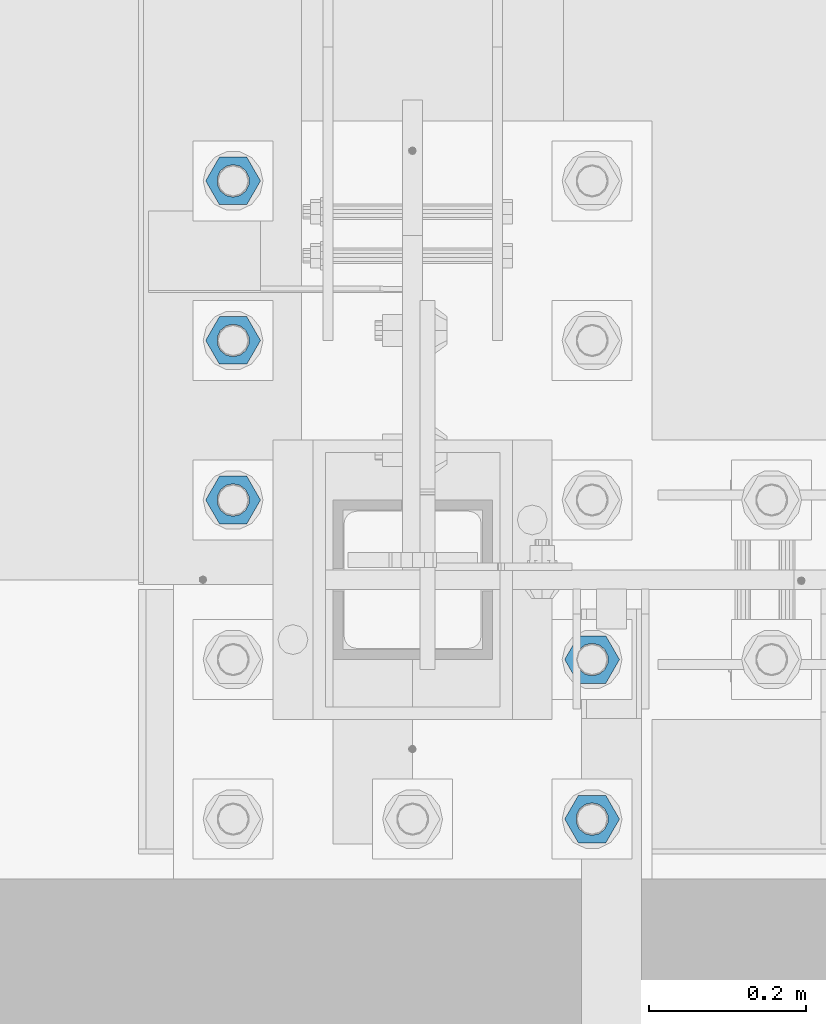
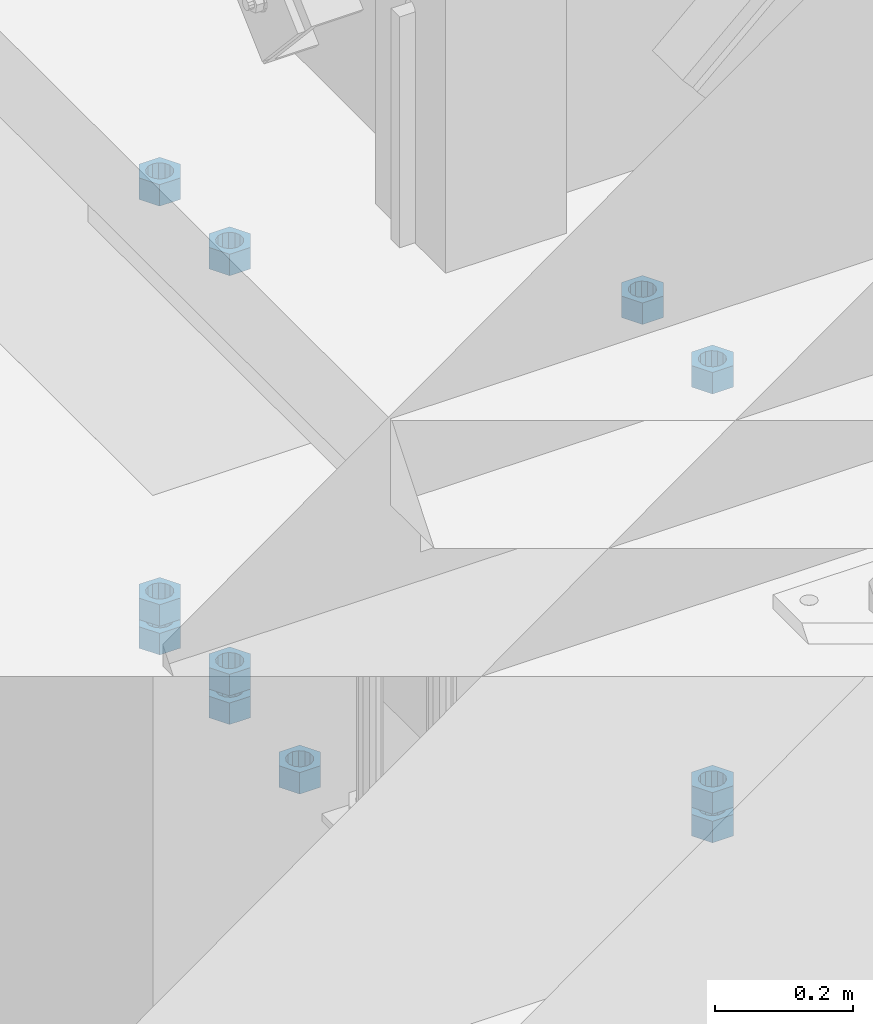
# One storey, part 979 of 1763: 11 columns, 1 element without a shape of its own.
"""IFC2X3 building model written with IfcOpenShell, lengths in millimetres."""

from ifc_helpers import new_model, si_unit, frame, origin_with_axes, place, context, subcontext, project, spatial, faceted_brep, material, type_object, element, aggregate, save


model = new_model("IFC2X3")

# Units and contexts
model_context = context("Model", 3, precision=1e-05, world=origin_with_axes())
body_context = subcontext(model_context, "Body", "Model", "MODEL_VIEW")
ifc_project = project(units=[si_unit("LENGTHUNIT", "METRE", prefix="MILLI"), si_unit("AREAUNIT", "SQUARE_METRE"), si_unit("VOLUMEUNIT", "CUBIC_METRE"), si_unit("MASSUNIT", "GRAM", prefix="KILO"), si_unit("TIMEUNIT", "SECOND"), si_unit("PLANEANGLEUNIT", "RADIAN"), si_unit("SOLIDANGLEUNIT", "STERADIAN"), si_unit("THERMODYNAMICTEMPERATUREUNIT", "DEGREE_CELSIUS"), si_unit("LUMINOUSINTENSITYUNIT", "LUMEN")], contexts=[model_context])

# Site, building, storey
site_placement = place(None, origin_with_axes())
site = spatial("IfcSite", under=ifc_project, at=site_placement, CompositionType="ELEMENT")
building_placement = place(site_placement, origin_with_axes())
building = spatial("IfcBuilding", under=site, at=building_placement, Name="Undefined", CompositionType="ELEMENT")
storey_placement = place(building_placement, origin_with_axes())
storey = spatial("IfcBuildingStorey", under=building, at=storey_placement, Name="Undefined", CompositionType="ELEMENT", Elevation=0.0)

# Assembly, columns
assembly_placement = place(storey_placement, origin_with_axes())
assembly = element("IfcElementAssembly", 1, at=assembly_placement, inside=storey, Name="TEMPLATE", AssemblyPlace="NOTDEFINED", PredefinedType="RIGID_FRAME")
ifc_material = material(Name="STEEL/A563")
column_type = type_object("IfcColumnType", Name="1-1/2_HEAVY_HEX_NUT", PredefinedType="NOTDEFINED")
column_1_placement = place(assembly_placement, frame((-87146.8372736983, -14020.8, 5189.53750000001), z_axis=(0.0, 1.0, 0.0), x_axis=(0.0, 0.0, -1.0)))
column_1 = element("IfcColumn", 2, at=column_1_placement, type_object=column_type, material=ifc_material, Name="NUT", ObjectType="1-1/2_HEAVY_HEX_NUT", context=body_context, shape_type="Brep", body=[
    faceted_brep([(0.0, -34.9199981689453, 0.0), (0.0, -17.4599990844727, -30.25), (38.1000000000004, -17.4599990844727, -30.25), (38.1000000000004, -34.9199981689453, 0.0), (0.0, 17.4599990844727, -30.25), (38.1000000000004, 17.4599990844727, -30.25), (0.0, 34.9199981689453, 0.0), (38.1000000000004, 34.9199981689453, 0.0), (0.0, 17.4599990844727, 30.25), (38.1000000000004, 17.4599990844727, 30.25), (0.0, -17.4599990844727, 30.25), (38.1000000000004, -17.4599990844727, 30.25), (0.0, 0.0, 20.6399993896484), (0.0, 8.95536011056538, 18.5959968835978), (38.1000000000004, 8.95536011056538, 18.5959968835978), (38.1000000000004, 0.0, 20.6399993896484), (0.0, 16.1370013209453, 12.8688291298167), (38.1000000000004, 16.1370013209453, 12.8688291298167), (0.0, 20.1225115123816, 4.59283194104137), (38.1000000000004, 20.1225115123816, 4.59283194104137), (0.0, 20.1225115123816, -4.59283194104319), (38.1000000000004, 20.1225115123816, -4.59283194104319), (0.0, 16.1370013209453, -12.8688291298167), (38.1000000000004, 16.1370013209453, -12.8688291298167), (0.0, 8.95536011056538, -18.5959968835978), (38.1000000000004, 8.95536011056538, -18.5959968835978), (0.0, 0.0, -20.6399993896484), (38.1000000000004, 0.0, -20.6399993896484), (0.0, -8.95536011056538, -18.5959968835978), (38.1000000000004, -8.95536011056538, -18.5959968835978), (0.0, -16.1370013209453, -12.8688291298167), (38.1000000000004, -16.1370013209453, -12.8688291298167), (0.0, -20.1225115123816, -4.59283194104137), (38.1000000000004, -20.1225115123816, -4.59283194104137), (0.0, -20.1225115123816, 4.59283194104319), (38.1000000000004, -20.1225115123816, 4.59283194104319), (0.0, -16.1370013209453, 12.8688291298167), (38.1000000000004, -16.1370013209453, 12.8688291298167), (0.0, -8.95536011056538, 18.5959968835978), (38.1000000000004, -8.95536011056538, 18.5959968835978)], [[[0, 1, 2, 3]], [[1, 4, 5, 2]], [[4, 6, 7, 5]], [[6, 8, 9, 7]], [[8, 10, 11, 9]], [[10, 0, 3, 11]], [[12, 13, 14, 15]], [[13, 16, 17, 14]], [[16, 18, 19, 17]], [[18, 20, 21, 19]], [[20, 22, 23, 21]], [[22, 24, 25, 23]], [[24, 26, 27, 25]], [[26, 28, 29, 27]], [[28, 30, 31, 29]], [[30, 32, 33, 31]], [[32, 34, 35, 33]], [[34, 36, 37, 35]], [[36, 38, 39, 37]], [[38, 12, 15, 39]], [[5, 7, 9, 11, 3, 2], [17, 19, 21, 23, 25, 27, 29, 31, 33, 35, 37, 39, 15, 14]], [[10, 8, 6, 4, 1, 0], [38, 36, 34, 32, 30, 28, 26, 24, 22, 20, 18, 16, 13, 12]]]),
])
column_2_placement = place(assembly_placement, frame((-87146.8372736983, -14020.8, 4445.00000000001), z_axis=(0.0, 1.0, 0.0), x_axis=(0.0, 0.0, -1.0)))
column_2 = element("IfcColumn", 3, at=column_2_placement, type_object=column_type, material=ifc_material, Name="NUT", ObjectType="1-1/2_HEAVY_HEX_NUT", context=body_context, shape_type="Brep", body=[
    faceted_brep([(0.0, -34.9199981689453, 0.0), (0.0, -17.4599990844727, -30.25), (38.1000000000004, -17.4599990844727, -30.25), (38.1000000000004, -34.9199981689453, 0.0), (0.0, 17.4599990844727, -30.25), (38.1000000000004, 17.4599990844727, -30.25), (0.0, 34.9199981689453, 0.0), (38.1000000000004, 34.9199981689453, 0.0), (0.0, 17.4599990844727, 30.25), (38.1000000000004, 17.4599990844727, 30.25), (0.0, -17.4599990844727, 30.25), (38.1000000000004, -17.4599990844727, 30.25), (0.0, 0.0, 20.6399993896484), (0.0, 8.95536011056538, 18.5959968835978), (38.1000000000004, 8.95536011056538, 18.5959968835978), (38.1000000000004, 0.0, 20.6399993896484), (0.0, 16.1370013209453, 12.8688291298167), (38.1000000000004, 16.1370013209453, 12.8688291298167), (0.0, 20.1225115123816, 4.59283194104137), (38.1000000000004, 20.1225115123816, 4.59283194104137), (0.0, 20.1225115123816, -4.59283194104319), (38.1000000000004, 20.1225115123816, -4.59283194104319), (0.0, 16.1370013209453, -12.8688291298167), (38.1000000000004, 16.1370013209453, -12.8688291298167), (0.0, 8.95536011056538, -18.5959968835978), (38.1000000000004, 8.95536011056538, -18.5959968835978), (0.0, 0.0, -20.6399993896484), (38.1000000000004, 0.0, -20.6399993896484), (0.0, -8.95536011056538, -18.5959968835978), (38.1000000000004, -8.95536011056538, -18.5959968835978), (0.0, -16.1370013209453, -12.8688291298167), (38.1000000000004, -16.1370013209453, -12.8688291298167), (0.0, -20.1225115123816, -4.59283194104137), (38.1000000000004, -20.1225115123816, -4.59283194104137), (0.0, -20.1225115123816, 4.59283194104319), (38.1000000000004, -20.1225115123816, 4.59283194104319), (0.0, -16.1370013209453, 12.8688291298167), (38.1000000000004, -16.1370013209453, 12.8688291298167), (0.0, -8.95536011056538, 18.5959968835978), (38.1000000000004, -8.95536011056538, 18.5959968835978)], [[[0, 1, 2, 3]], [[1, 4, 5, 2]], [[4, 6, 7, 5]], [[6, 8, 9, 7]], [[8, 10, 11, 9]], [[10, 0, 3, 11]], [[12, 13, 14, 15]], [[13, 16, 17, 14]], [[16, 18, 19, 17]], [[18, 20, 21, 19]], [[20, 22, 23, 21]], [[22, 24, 25, 23]], [[24, 26, 27, 25]], [[26, 28, 29, 27]], [[28, 30, 31, 29]], [[30, 32, 33, 31]], [[32, 34, 35, 33]], [[34, 36, 37, 35]], [[36, 38, 39, 37]], [[38, 12, 15, 39]], [[5, 7, 9, 11, 3, 2], [17, 19, 21, 23, 25, 27, 29, 31, 33, 35, 37, 39, 15, 14]], [[10, 8, 6, 4, 1, 0], [38, 36, 34, 32, 30, 28, 26, 24, 22, 20, 18, 16, 13, 12]]]),
])
column_3_placement = place(assembly_placement, frame((-87146.8372736983, -14020.8, 4394.20000000001), z_axis=(0.0, 1.0, 0.0), x_axis=(0.0, 0.0, -1.0)))
column_3 = element("IfcColumn", 4, at=column_3_placement, type_object=column_type, material=ifc_material, Name="NUT", ObjectType="1-1/2_HEAVY_HEX_NUT", context=body_context, shape_type="Brep", body=[
    faceted_brep([(0.0, -34.9199981689453, 0.0), (0.0, -17.4599990844727, -30.25), (38.1000000000004, -17.4599990844727, -30.25), (38.1000000000004, -34.9199981689453, 0.0), (0.0, 17.4599990844727, -30.25), (38.1000000000004, 17.4599990844727, -30.25), (0.0, 34.9199981689453, 0.0), (38.1000000000004, 34.9199981689453, 0.0), (0.0, 17.4599990844727, 30.25), (38.1000000000004, 17.4599990844727, 30.25), (0.0, -17.4599990844727, 30.25), (38.1000000000004, -17.4599990844727, 30.25), (0.0, 0.0, 20.6399993896484), (0.0, 8.95536011056538, 18.5959968835978), (38.1000000000004, 8.95536011056538, 18.5959968835978), (38.1000000000004, 0.0, 20.6399993896484), (0.0, 16.1370013209453, 12.8688291298167), (38.1000000000004, 16.1370013209453, 12.8688291298167), (0.0, 20.1225115123816, 4.59283194104137), (38.1000000000004, 20.1225115123816, 4.59283194104137), (0.0, 20.1225115123816, -4.59283194104319), (38.1000000000004, 20.1225115123816, -4.59283194104319), (0.0, 16.1370013209453, -12.8688291298167), (38.1000000000004, 16.1370013209453, -12.8688291298167), (0.0, 8.95536011056538, -18.5959968835978), (38.1000000000004, 8.95536011056538, -18.5959968835978), (0.0, 0.0, -20.6399993896484), (38.1000000000004, 0.0, -20.6399993896484), (0.0, -8.95536011056538, -18.5959968835978), (38.1000000000004, -8.95536011056538, -18.5959968835978), (0.0, -16.1370013209453, -12.8688291298167), (38.1000000000004, -16.1370013209453, -12.8688291298167), (0.0, -20.1225115123816, -4.59283194104137), (38.1000000000004, -20.1225115123816, -4.59283194104137), (0.0, -20.1225115123816, 4.59283194104319), (38.1000000000004, -20.1225115123816, 4.59283194104319), (0.0, -16.1370013209453, 12.8688291298167), (38.1000000000004, -16.1370013209453, 12.8688291298167), (0.0, -8.95536011056538, 18.5959968835978), (38.1000000000004, -8.95536011056538, 18.5959968835978)], [[[0, 1, 2, 3]], [[1, 4, 5, 2]], [[4, 6, 7, 5]], [[6, 8, 9, 7]], [[8, 10, 11, 9]], [[10, 0, 3, 11]], [[12, 13, 14, 15]], [[13, 16, 17, 14]], [[16, 18, 19, 17]], [[18, 20, 21, 19]], [[20, 22, 23, 21]], [[22, 24, 25, 23]], [[24, 26, 27, 25]], [[26, 28, 29, 27]], [[28, 30, 31, 29]], [[30, 32, 33, 31]], [[32, 34, 35, 33]], [[34, 36, 37, 35]], [[36, 38, 39, 37]], [[38, 12, 15, 39]], [[5, 7, 9, 11, 3, 2], [17, 19, 21, 23, 25, 27, 29, 31, 33, 35, 37, 39, 15, 14]], [[10, 8, 6, 4, 1, 0], [38, 36, 34, 32, 30, 28, 26, 24, 22, 20, 18, 16, 13, 12]]]),
])
column_4_placement = place(assembly_placement, frame((-87146.8372736983, -13817.6, 5189.53750000001), z_axis=(0.0, 1.0, 0.0), x_axis=(0.0, 0.0, -1.0)))
column_4 = element("IfcColumn", 5, at=column_4_placement, type_object=column_type, material=ifc_material, Name="NUT", ObjectType="1-1/2_HEAVY_HEX_NUT", context=body_context, shape_type="Brep", body=[
    faceted_brep([(0.0, -34.9199981689453, 0.0), (0.0, -17.4599990844727, -30.25), (38.1000000000004, -17.4599990844727, -30.25), (38.1000000000004, -34.9199981689453, 0.0), (0.0, 17.4599990844727, -30.25), (38.1000000000004, 17.4599990844727, -30.25), (0.0, 34.9199981689453, 0.0), (38.1000000000004, 34.9199981689453, 0.0), (0.0, 17.4599990844727, 30.25), (38.1000000000004, 17.4599990844727, 30.25), (0.0, -17.4599990844727, 30.25), (38.1000000000004, -17.4599990844727, 30.25), (0.0, 0.0, 20.6399993896484), (0.0, 8.95536011056538, 18.5959968835978), (38.1000000000004, 8.95536011056538, 18.5959968835978), (38.1000000000004, 0.0, 20.6399993896484), (0.0, 16.1370013209453, 12.8688291298167), (38.1000000000004, 16.1370013209453, 12.8688291298167), (0.0, 20.1225115123816, 4.59283194104137), (38.1000000000004, 20.1225115123816, 4.59283194104137), (0.0, 20.1225115123816, -4.59283194104319), (38.1000000000004, 20.1225115123816, -4.59283194104319), (0.0, 16.1370013209453, -12.8688291298167), (38.1000000000004, 16.1370013209453, -12.8688291298167), (0.0, 8.95536011056538, -18.5959968835978), (38.1000000000004, 8.95536011056538, -18.5959968835978), (0.0, 0.0, -20.6399993896484), (38.1000000000004, 0.0, -20.6399993896484), (0.0, -8.95536011056538, -18.5959968835978), (38.1000000000004, -8.95536011056538, -18.5959968835978), (0.0, -16.1370013209453, -12.8688291298167), (38.1000000000004, -16.1370013209453, -12.8688291298167), (0.0, -20.1225115123816, -4.59283194104137), (38.1000000000004, -20.1225115123816, -4.59283194104137), (0.0, -20.1225115123816, 4.59283194104319), (38.1000000000004, -20.1225115123816, 4.59283194104319), (0.0, -16.1370013209453, 12.8688291298167), (38.1000000000004, -16.1370013209453, 12.8688291298167), (0.0, -8.95536011056538, 18.5959968835978), (38.1000000000004, -8.95536011056538, 18.5959968835978)], [[[0, 1, 2, 3]], [[1, 4, 5, 2]], [[4, 6, 7, 5]], [[6, 8, 9, 7]], [[8, 10, 11, 9]], [[10, 0, 3, 11]], [[12, 13, 14, 15]], [[13, 16, 17, 14]], [[16, 18, 19, 17]], [[18, 20, 21, 19]], [[20, 22, 23, 21]], [[22, 24, 25, 23]], [[24, 26, 27, 25]], [[26, 28, 29, 27]], [[28, 30, 31, 29]], [[30, 32, 33, 31]], [[32, 34, 35, 33]], [[34, 36, 37, 35]], [[36, 38, 39, 37]], [[38, 12, 15, 39]], [[5, 7, 9, 11, 3, 2], [17, 19, 21, 23, 25, 27, 29, 31, 33, 35, 37, 39, 15, 14]], [[10, 8, 6, 4, 1, 0], [38, 36, 34, 32, 30, 28, 26, 24, 22, 20, 18, 16, 13, 12]]]),
])
column_5_placement = place(assembly_placement, frame((-87604.0372736983, -13614.4, 4394.20000000001), z_axis=(0.0, -1.0, 0.0), x_axis=(0.0, 0.0, -1.0)))
column_5 = element("IfcColumn", 6, at=column_5_placement, type_object=column_type, material=ifc_material, Name="NUT", ObjectType="1-1/2_HEAVY_HEX_NUT", context=body_context, shape_type="Brep", body=[
    faceted_brep([(0.0, -34.9199981689453, 0.0), (0.0, -17.4599990844727, -30.25), (38.1000000000004, -17.4599990844727, -30.25), (38.1000000000004, -34.9199981689453, 0.0), (0.0, 17.4599990844727, -30.25), (38.1000000000004, 17.4599990844727, -30.25), (0.0, 34.9199981689453, 0.0), (38.1000000000004, 34.9199981689453, 0.0), (0.0, 17.4599990844727, 30.25), (38.1000000000004, 17.4599990844727, 30.25), (0.0, -17.4599990844727, 30.25), (38.1000000000004, -17.4599990844727, 30.25), (0.0, 0.0, 20.6399993896484), (0.0, 8.95536011056538, 18.5959968835978), (38.1000000000004, 8.95536011056538, 18.5959968835978), (38.1000000000004, 0.0, 20.6399993896484), (0.0, 16.1370013209453, 12.8688291298167), (38.1000000000004, 16.1370013209453, 12.8688291298167), (0.0, 20.1225115123816, 4.59283194104137), (38.1000000000004, 20.1225115123816, 4.59283194104137), (0.0, 20.1225115123816, -4.59283194104319), (38.1000000000004, 20.1225115123816, -4.59283194104319), (0.0, 16.1370013209453, -12.8688291298167), (38.1000000000004, 16.1370013209453, -12.8688291298167), (0.0, 8.95536011056538, -18.5959968835978), (38.1000000000004, 8.95536011056538, -18.5959968835978), (0.0, 0.0, -20.6399993896484), (38.1000000000004, 0.0, -20.6399993896484), (0.0, -8.95536011056538, -18.5959968835978), (38.1000000000004, -8.95536011056538, -18.5959968835978), (0.0, -16.1370013209453, -12.8688291298167), (38.1000000000004, -16.1370013209453, -12.8688291298167), (0.0, -20.1225115123816, -4.59283194104137), (38.1000000000004, -20.1225115123816, -4.59283194104137), (0.0, -20.1225115123816, 4.59283194104319), (38.1000000000004, -20.1225115123816, 4.59283194104319), (0.0, -16.1370013209453, 12.8688291298167), (38.1000000000004, -16.1370013209453, 12.8688291298167), (0.0, -8.95536011056538, 18.5959968835978), (38.1000000000004, -8.95536011056538, 18.5959968835978)], [[[0, 1, 2, 3]], [[1, 4, 5, 2]], [[4, 6, 7, 5]], [[6, 8, 9, 7]], [[8, 10, 11, 9]], [[10, 0, 3, 11]], [[12, 13, 14, 15]], [[13, 16, 17, 14]], [[16, 18, 19, 17]], [[18, 20, 21, 19]], [[20, 22, 23, 21]], [[22, 24, 25, 23]], [[24, 26, 27, 25]], [[26, 28, 29, 27]], [[28, 30, 31, 29]], [[30, 32, 33, 31]], [[32, 34, 35, 33]], [[34, 36, 37, 35]], [[36, 38, 39, 37]], [[38, 12, 15, 39]], [[5, 7, 9, 11, 3, 2], [17, 19, 21, 23, 25, 27, 29, 31, 33, 35, 37, 39, 15, 14]], [[10, 8, 6, 4, 1, 0], [38, 36, 34, 32, 30, 28, 26, 24, 22, 20, 18, 16, 13, 12]]]),
])
column_6_placement = place(assembly_placement, frame((-87604.0372736983, -13411.2, 5189.53750000001), z_axis=(0.0, -1.0, 0.0), x_axis=(0.0, 0.0, -1.0)))
column_6 = element("IfcColumn", 7, at=column_6_placement, type_object=column_type, material=ifc_material, Name="NUT", ObjectType="1-1/2_HEAVY_HEX_NUT", context=body_context, shape_type="Brep", body=[
    faceted_brep([(0.0, -34.9199981689453, 0.0), (0.0, -17.4599990844727, -30.25), (38.1000000000004, -17.4599990844727, -30.25), (38.1000000000004, -34.9199981689453, 0.0), (0.0, 17.4599990844727, -30.25), (38.1000000000004, 17.4599990844727, -30.25), (0.0, 34.9199981689453, 0.0), (38.1000000000004, 34.9199981689453, 0.0), (0.0, 17.4599990844727, 30.25), (38.1000000000004, 17.4599990844727, 30.25), (0.0, -17.4599990844727, 30.25), (38.1000000000004, -17.4599990844727, 30.25), (0.0, 0.0, 20.6399993896484), (0.0, 8.95536011056538, 18.5959968835978), (38.1000000000004, 8.95536011056538, 18.5959968835978), (38.1000000000004, 0.0, 20.6399993896484), (0.0, 16.1370013209453, 12.8688291298167), (38.1000000000004, 16.1370013209453, 12.8688291298167), (0.0, 20.1225115123816, 4.59283194104137), (38.1000000000004, 20.1225115123816, 4.59283194104137), (0.0, 20.1225115123816, -4.59283194104319), (38.1000000000004, 20.1225115123816, -4.59283194104319), (0.0, 16.1370013209453, -12.8688291298167), (38.1000000000004, 16.1370013209453, -12.8688291298167), (0.0, 8.95536011056538, -18.5959968835978), (38.1000000000004, 8.95536011056538, -18.5959968835978), (0.0, 0.0, -20.6399993896484), (38.1000000000004, 0.0, -20.6399993896484), (0.0, -8.95536011056538, -18.5959968835978), (38.1000000000004, -8.95536011056538, -18.5959968835978), (0.0, -16.1370013209453, -12.8688291298167), (38.1000000000004, -16.1370013209453, -12.8688291298167), (0.0, -20.1225115123816, -4.59283194104137), (38.1000000000004, -20.1225115123816, -4.59283194104137), (0.0, -20.1225115123816, 4.59283194104319), (38.1000000000004, -20.1225115123816, 4.59283194104319), (0.0, -16.1370013209453, 12.8688291298167), (38.1000000000004, -16.1370013209453, 12.8688291298167), (0.0, -8.95536011056538, 18.5959968835978), (38.1000000000004, -8.95536011056538, 18.5959968835978)], [[[0, 1, 2, 3]], [[1, 4, 5, 2]], [[4, 6, 7, 5]], [[6, 8, 9, 7]], [[8, 10, 11, 9]], [[10, 0, 3, 11]], [[12, 13, 14, 15]], [[13, 16, 17, 14]], [[16, 18, 19, 17]], [[18, 20, 21, 19]], [[20, 22, 23, 21]], [[22, 24, 25, 23]], [[24, 26, 27, 25]], [[26, 28, 29, 27]], [[28, 30, 31, 29]], [[30, 32, 33, 31]], [[32, 34, 35, 33]], [[34, 36, 37, 35]], [[36, 38, 39, 37]], [[38, 12, 15, 39]], [[5, 7, 9, 11, 3, 2], [17, 19, 21, 23, 25, 27, 29, 31, 33, 35, 37, 39, 15, 14]], [[10, 8, 6, 4, 1, 0], [38, 36, 34, 32, 30, 28, 26, 24, 22, 20, 18, 16, 13, 12]]]),
])
column_7_placement = place(assembly_placement, frame((-87604.0372736983, -13411.2, 4445.00000000001), z_axis=(0.0, -1.0, 0.0), x_axis=(0.0, 0.0, -1.0)))
column_7 = element("IfcColumn", 8, at=column_7_placement, type_object=column_type, material=ifc_material, Name="NUT", ObjectType="1-1/2_HEAVY_HEX_NUT", context=body_context, shape_type="Brep", body=[
    faceted_brep([(0.0, -34.9199981689453, 0.0), (0.0, -17.4599990844727, -30.25), (38.1000000000004, -17.4599990844727, -30.25), (38.1000000000004, -34.9199981689453, 0.0), (0.0, 17.4599990844727, -30.25), (38.1000000000004, 17.4599990844727, -30.25), (0.0, 34.9199981689453, 0.0), (38.1000000000004, 34.9199981689453, 0.0), (0.0, 17.4599990844727, 30.25), (38.1000000000004, 17.4599990844727, 30.25), (0.0, -17.4599990844727, 30.25), (38.1000000000004, -17.4599990844727, 30.25), (0.0, 0.0, 20.6399993896484), (0.0, 8.95536011056538, 18.5959968835978), (38.1000000000004, 8.95536011056538, 18.5959968835978), (38.1000000000004, 0.0, 20.6399993896484), (0.0, 16.1370013209453, 12.8688291298167), (38.1000000000004, 16.1370013209453, 12.8688291298167), (0.0, 20.1225115123816, 4.59283194104137), (38.1000000000004, 20.1225115123816, 4.59283194104137), (0.0, 20.1225115123816, -4.59283194104319), (38.1000000000004, 20.1225115123816, -4.59283194104319), (0.0, 16.1370013209453, -12.8688291298167), (38.1000000000004, 16.1370013209453, -12.8688291298167), (0.0, 8.95536011056538, -18.5959968835978), (38.1000000000004, 8.95536011056538, -18.5959968835978), (0.0, 0.0, -20.6399993896484), (38.1000000000004, 0.0, -20.6399993896484), (0.0, -8.95536011056538, -18.5959968835978), (38.1000000000004, -8.95536011056538, -18.5959968835978), (0.0, -16.1370013209453, -12.8688291298167), (38.1000000000004, -16.1370013209453, -12.8688291298167), (0.0, -20.1225115123816, -4.59283194104137), (38.1000000000004, -20.1225115123816, -4.59283194104137), (0.0, -20.1225115123816, 4.59283194104319), (38.1000000000004, -20.1225115123816, 4.59283194104319), (0.0, -16.1370013209453, 12.8688291298167), (38.1000000000004, -16.1370013209453, 12.8688291298167), (0.0, -8.95536011056538, 18.5959968835978), (38.1000000000004, -8.95536011056538, 18.5959968835978)], [[[0, 1, 2, 3]], [[1, 4, 5, 2]], [[4, 6, 7, 5]], [[6, 8, 9, 7]], [[8, 10, 11, 9]], [[10, 0, 3, 11]], [[12, 13, 14, 15]], [[13, 16, 17, 14]], [[16, 18, 19, 17]], [[18, 20, 21, 19]], [[20, 22, 23, 21]], [[22, 24, 25, 23]], [[24, 26, 27, 25]], [[26, 28, 29, 27]], [[28, 30, 31, 29]], [[30, 32, 33, 31]], [[32, 34, 35, 33]], [[34, 36, 37, 35]], [[36, 38, 39, 37]], [[38, 12, 15, 39]], [[5, 7, 9, 11, 3, 2], [17, 19, 21, 23, 25, 27, 29, 31, 33, 35, 37, 39, 15, 14]], [[10, 8, 6, 4, 1, 0], [38, 36, 34, 32, 30, 28, 26, 24, 22, 20, 18, 16, 13, 12]]]),
])
column_8_placement = place(assembly_placement, frame((-87604.0372736983, -13411.2, 4394.20000000001), z_axis=(0.0, -1.0, 0.0), x_axis=(0.0, 0.0, -1.0)))
column_8 = element("IfcColumn", 9, at=column_8_placement, type_object=column_type, material=ifc_material, Name="NUT", ObjectType="1-1/2_HEAVY_HEX_NUT", context=body_context, shape_type="Brep", body=[
    faceted_brep([(0.0, -34.9199981689453, 0.0), (0.0, -17.4599990844727, -30.25), (38.1000000000004, -17.4599990844727, -30.25), (38.1000000000004, -34.9199981689453, 0.0), (0.0, 17.4599990844727, -30.25), (38.1000000000004, 17.4599990844727, -30.25), (0.0, 34.9199981689453, 0.0), (38.1000000000004, 34.9199981689453, 0.0), (0.0, 17.4599990844727, 30.25), (38.1000000000004, 17.4599990844727, 30.25), (0.0, -17.4599990844727, 30.25), (38.1000000000004, -17.4599990844727, 30.25), (0.0, 0.0, 20.6399993896484), (0.0, 8.95536011056538, 18.5959968835978), (38.1000000000004, 8.95536011056538, 18.5959968835978), (38.1000000000004, 0.0, 20.6399993896484), (0.0, 16.1370013209453, 12.8688291298167), (38.1000000000004, 16.1370013209453, 12.8688291298167), (0.0, 20.1225115123816, 4.59283194104137), (38.1000000000004, 20.1225115123816, 4.59283194104137), (0.0, 20.1225115123816, -4.59283194104319), (38.1000000000004, 20.1225115123816, -4.59283194104319), (0.0, 16.1370013209453, -12.8688291298167), (38.1000000000004, 16.1370013209453, -12.8688291298167), (0.0, 8.95536011056538, -18.5959968835978), (38.1000000000004, 8.95536011056538, -18.5959968835978), (0.0, 0.0, -20.6399993896484), (38.1000000000004, 0.0, -20.6399993896484), (0.0, -8.95536011056538, -18.5959968835978), (38.1000000000004, -8.95536011056538, -18.5959968835978), (0.0, -16.1370013209453, -12.8688291298167), (38.1000000000004, -16.1370013209453, -12.8688291298167), (0.0, -20.1225115123816, -4.59283194104137), (38.1000000000004, -20.1225115123816, -4.59283194104137), (0.0, -20.1225115123816, 4.59283194104319), (38.1000000000004, -20.1225115123816, 4.59283194104319), (0.0, -16.1370013209453, 12.8688291298167), (38.1000000000004, -16.1370013209453, 12.8688291298167), (0.0, -8.95536011056538, 18.5959968835978), (38.1000000000004, -8.95536011056538, 18.5959968835978)], [[[0, 1, 2, 3]], [[1, 4, 5, 2]], [[4, 6, 7, 5]], [[6, 8, 9, 7]], [[8, 10, 11, 9]], [[10, 0, 3, 11]], [[12, 13, 14, 15]], [[13, 16, 17, 14]], [[16, 18, 19, 17]], [[18, 20, 21, 19]], [[20, 22, 23, 21]], [[22, 24, 25, 23]], [[24, 26, 27, 25]], [[26, 28, 29, 27]], [[28, 30, 31, 29]], [[30, 32, 33, 31]], [[32, 34, 35, 33]], [[34, 36, 37, 35]], [[36, 38, 39, 37]], [[38, 12, 15, 39]], [[5, 7, 9, 11, 3, 2], [17, 19, 21, 23, 25, 27, 29, 31, 33, 35, 37, 39, 15, 14]], [[10, 8, 6, 4, 1, 0], [38, 36, 34, 32, 30, 28, 26, 24, 22, 20, 18, 16, 13, 12]]]),
])
column_9_placement = place(assembly_placement, frame((-87604.0372736983, -13208.0, 5189.53750000001), z_axis=(0.0, -1.0, 0.0), x_axis=(0.0, 0.0, -1.0)))
column_9 = element("IfcColumn", 10, at=column_9_placement, type_object=column_type, material=ifc_material, Name="NUT", ObjectType="1-1/2_HEAVY_HEX_NUT", context=body_context, shape_type="Brep", body=[
    faceted_brep([(0.0, -34.9199981689453, 0.0), (0.0, -17.4599990844727, -30.25), (38.1000000000004, -17.4599990844727, -30.25), (38.1000000000004, -34.9199981689453, 0.0), (0.0, 17.4599990844727, -30.25), (38.1000000000004, 17.4599990844727, -30.25), (0.0, 34.9199981689453, 0.0), (38.1000000000004, 34.9199981689453, 0.0), (0.0, 17.4599990844727, 30.25), (38.1000000000004, 17.4599990844727, 30.25), (0.0, -17.4599990844727, 30.25), (38.1000000000004, -17.4599990844727, 30.25), (0.0, 0.0, 20.6399993896484), (0.0, 8.95536011056538, 18.5959968835978), (38.1000000000004, 8.95536011056538, 18.5959968835978), (38.1000000000004, 0.0, 20.6399993896484), (0.0, 16.1370013209453, 12.8688291298167), (38.1000000000004, 16.1370013209453, 12.8688291298167), (0.0, 20.1225115123816, 4.59283194104137), (38.1000000000004, 20.1225115123816, 4.59283194104137), (0.0, 20.1225115123816, -4.59283194104319), (38.1000000000004, 20.1225115123816, -4.59283194104319), (0.0, 16.1370013209453, -12.8688291298167), (38.1000000000004, 16.1370013209453, -12.8688291298167), (0.0, 8.95536011056538, -18.5959968835978), (38.1000000000004, 8.95536011056538, -18.5959968835978), (0.0, 0.0, -20.6399993896484), (38.1000000000004, 0.0, -20.6399993896484), (0.0, -8.95536011056538, -18.5959968835978), (38.1000000000004, -8.95536011056538, -18.5959968835978), (0.0, -16.1370013209453, -12.8688291298167), (38.1000000000004, -16.1370013209453, -12.8688291298167), (0.0, -20.1225115123816, -4.59283194104137), (38.1000000000004, -20.1225115123816, -4.59283194104137), (0.0, -20.1225115123816, 4.59283194104319), (38.1000000000004, -20.1225115123816, 4.59283194104319), (0.0, -16.1370013209453, 12.8688291298167), (38.1000000000004, -16.1370013209453, 12.8688291298167), (0.0, -8.95536011056538, 18.5959968835978), (38.1000000000004, -8.95536011056538, 18.5959968835978)], [[[0, 1, 2, 3]], [[1, 4, 5, 2]], [[4, 6, 7, 5]], [[6, 8, 9, 7]], [[8, 10, 11, 9]], [[10, 0, 3, 11]], [[12, 13, 14, 15]], [[13, 16, 17, 14]], [[16, 18, 19, 17]], [[18, 20, 21, 19]], [[20, 22, 23, 21]], [[22, 24, 25, 23]], [[24, 26, 27, 25]], [[26, 28, 29, 27]], [[28, 30, 31, 29]], [[30, 32, 33, 31]], [[32, 34, 35, 33]], [[34, 36, 37, 35]], [[36, 38, 39, 37]], [[38, 12, 15, 39]], [[5, 7, 9, 11, 3, 2], [17, 19, 21, 23, 25, 27, 29, 31, 33, 35, 37, 39, 15, 14]], [[10, 8, 6, 4, 1, 0], [38, 36, 34, 32, 30, 28, 26, 24, 22, 20, 18, 16, 13, 12]]]),
])
column_10_placement = place(assembly_placement, frame((-87604.0372736983, -13208.0, 4445.00000000001), z_axis=(0.0, -1.0, 0.0), x_axis=(0.0, 0.0, -1.0)))
column_10 = element("IfcColumn", 11, at=column_10_placement, type_object=column_type, material=ifc_material, Name="NUT", ObjectType="1-1/2_HEAVY_HEX_NUT", context=body_context, shape_type="Brep", body=[
    faceted_brep([(0.0, -34.9199981689453, 0.0), (0.0, -17.4599990844727, -30.25), (38.1000000000004, -17.4599990844727, -30.25), (38.1000000000004, -34.9199981689453, 0.0), (0.0, 17.4599990844727, -30.25), (38.1000000000004, 17.4599990844727, -30.25), (0.0, 34.9199981689453, 0.0), (38.1000000000004, 34.9199981689453, 0.0), (0.0, 17.4599990844727, 30.25), (38.1000000000004, 17.4599990844727, 30.25), (0.0, -17.4599990844727, 30.25), (38.1000000000004, -17.4599990844727, 30.25), (0.0, 0.0, 20.6399993896484), (0.0, 8.95536011056538, 18.5959968835978), (38.1000000000004, 8.95536011056538, 18.5959968835978), (38.1000000000004, 0.0, 20.6399993896484), (0.0, 16.1370013209453, 12.8688291298167), (38.1000000000004, 16.1370013209453, 12.8688291298167), (0.0, 20.1225115123816, 4.59283194104137), (38.1000000000004, 20.1225115123816, 4.59283194104137), (0.0, 20.1225115123816, -4.59283194104319), (38.1000000000004, 20.1225115123816, -4.59283194104319), (0.0, 16.1370013209453, -12.8688291298167), (38.1000000000004, 16.1370013209453, -12.8688291298167), (0.0, 8.95536011056538, -18.5959968835978), (38.1000000000004, 8.95536011056538, -18.5959968835978), (0.0, 0.0, -20.6399993896484), (38.1000000000004, 0.0, -20.6399993896484), (0.0, -8.95536011056538, -18.5959968835978), (38.1000000000004, -8.95536011056538, -18.5959968835978), (0.0, -16.1370013209453, -12.8688291298167), (38.1000000000004, -16.1370013209453, -12.8688291298167), (0.0, -20.1225115123816, -4.59283194104137), (38.1000000000004, -20.1225115123816, -4.59283194104137), (0.0, -20.1225115123816, 4.59283194104319), (38.1000000000004, -20.1225115123816, 4.59283194104319), (0.0, -16.1370013209453, 12.8688291298167), (38.1000000000004, -16.1370013209453, 12.8688291298167), (0.0, -8.95536011056538, 18.5959968835978), (38.1000000000004, -8.95536011056538, 18.5959968835978)], [[[0, 1, 2, 3]], [[1, 4, 5, 2]], [[4, 6, 7, 5]], [[6, 8, 9, 7]], [[8, 10, 11, 9]], [[10, 0, 3, 11]], [[12, 13, 14, 15]], [[13, 16, 17, 14]], [[16, 18, 19, 17]], [[18, 20, 21, 19]], [[20, 22, 23, 21]], [[22, 24, 25, 23]], [[24, 26, 27, 25]], [[26, 28, 29, 27]], [[28, 30, 31, 29]], [[30, 32, 33, 31]], [[32, 34, 35, 33]], [[34, 36, 37, 35]], [[36, 38, 39, 37]], [[38, 12, 15, 39]], [[5, 7, 9, 11, 3, 2], [17, 19, 21, 23, 25, 27, 29, 31, 33, 35, 37, 39, 15, 14]], [[10, 8, 6, 4, 1, 0], [38, 36, 34, 32, 30, 28, 26, 24, 22, 20, 18, 16, 13, 12]]]),
])
column_11_placement = place(assembly_placement, frame((-87604.0372736983, -13208.0, 4394.20000000001), z_axis=(0.0, -1.0, 0.0), x_axis=(0.0, 0.0, -1.0)))
column_11 = element("IfcColumn", 12, at=column_11_placement, type_object=column_type, material=ifc_material, Name="NUT", ObjectType="1-1/2_HEAVY_HEX_NUT", context=body_context, shape_type="Brep", body=[
    faceted_brep([(0.0, -34.9199981689453, 0.0), (0.0, -17.4599990844727, -30.25), (38.1000000000004, -17.4599990844727, -30.25), (38.1000000000004, -34.9199981689453, 0.0), (0.0, 17.4599990844727, -30.25), (38.1000000000004, 17.4599990844727, -30.25), (0.0, 34.9199981689453, 0.0), (38.1000000000004, 34.9199981689453, 0.0), (0.0, 17.4599990844727, 30.25), (38.1000000000004, 17.4599990844727, 30.25), (0.0, -17.4599990844727, 30.25), (38.1000000000004, -17.4599990844727, 30.25), (0.0, 0.0, 20.6399993896484), (0.0, 8.95536011056538, 18.5959968835978), (38.1000000000004, 8.95536011056538, 18.5959968835978), (38.1000000000004, 0.0, 20.6399993896484), (0.0, 16.1370013209453, 12.8688291298167), (38.1000000000004, 16.1370013209453, 12.8688291298167), (0.0, 20.1225115123816, 4.59283194104137), (38.1000000000004, 20.1225115123816, 4.59283194104137), (0.0, 20.1225115123816, -4.59283194104319), (38.1000000000004, 20.1225115123816, -4.59283194104319), (0.0, 16.1370013209453, -12.8688291298167), (38.1000000000004, 16.1370013209453, -12.8688291298167), (0.0, 8.95536011056538, -18.5959968835978), (38.1000000000004, 8.95536011056538, -18.5959968835978), (0.0, 0.0, -20.6399993896484), (38.1000000000004, 0.0, -20.6399993896484), (0.0, -8.95536011056538, -18.5959968835978), (38.1000000000004, -8.95536011056538, -18.5959968835978), (0.0, -16.1370013209453, -12.8688291298167), (38.1000000000004, -16.1370013209453, -12.8688291298167), (0.0, -20.1225115123816, -4.59283194104137), (38.1000000000004, -20.1225115123816, -4.59283194104137), (0.0, -20.1225115123816, 4.59283194104319), (38.1000000000004, -20.1225115123816, 4.59283194104319), (0.0, -16.1370013209453, 12.8688291298167), (38.1000000000004, -16.1370013209453, 12.8688291298167), (0.0, -8.95536011056538, 18.5959968835978), (38.1000000000004, -8.95536011056538, 18.5959968835978)], [[[0, 1, 2, 3]], [[1, 4, 5, 2]], [[4, 6, 7, 5]], [[6, 8, 9, 7]], [[8, 10, 11, 9]], [[10, 0, 3, 11]], [[12, 13, 14, 15]], [[13, 16, 17, 14]], [[16, 18, 19, 17]], [[18, 20, 21, 19]], [[20, 22, 23, 21]], [[22, 24, 25, 23]], [[24, 26, 27, 25]], [[26, 28, 29, 27]], [[28, 30, 31, 29]], [[30, 32, 33, 31]], [[32, 34, 35, 33]], [[34, 36, 37, 35]], [[36, 38, 39, 37]], [[38, 12, 15, 39]], [[5, 7, 9, 11, 3, 2], [17, 19, 21, 23, 25, 27, 29, 31, 33, 35, 37, 39, 15, 14]], [[10, 8, 6, 4, 1, 0], [38, 36, 34, 32, 30, 28, 26, 24, 22, 20, 18, 16, 13, 12]]]),
])
aggregate(assembly, [column_1, column_2, column_3, column_4, column_5, column_6, column_7, column_8, column_9, column_10, column_11])

save(model, "model.ifc")
